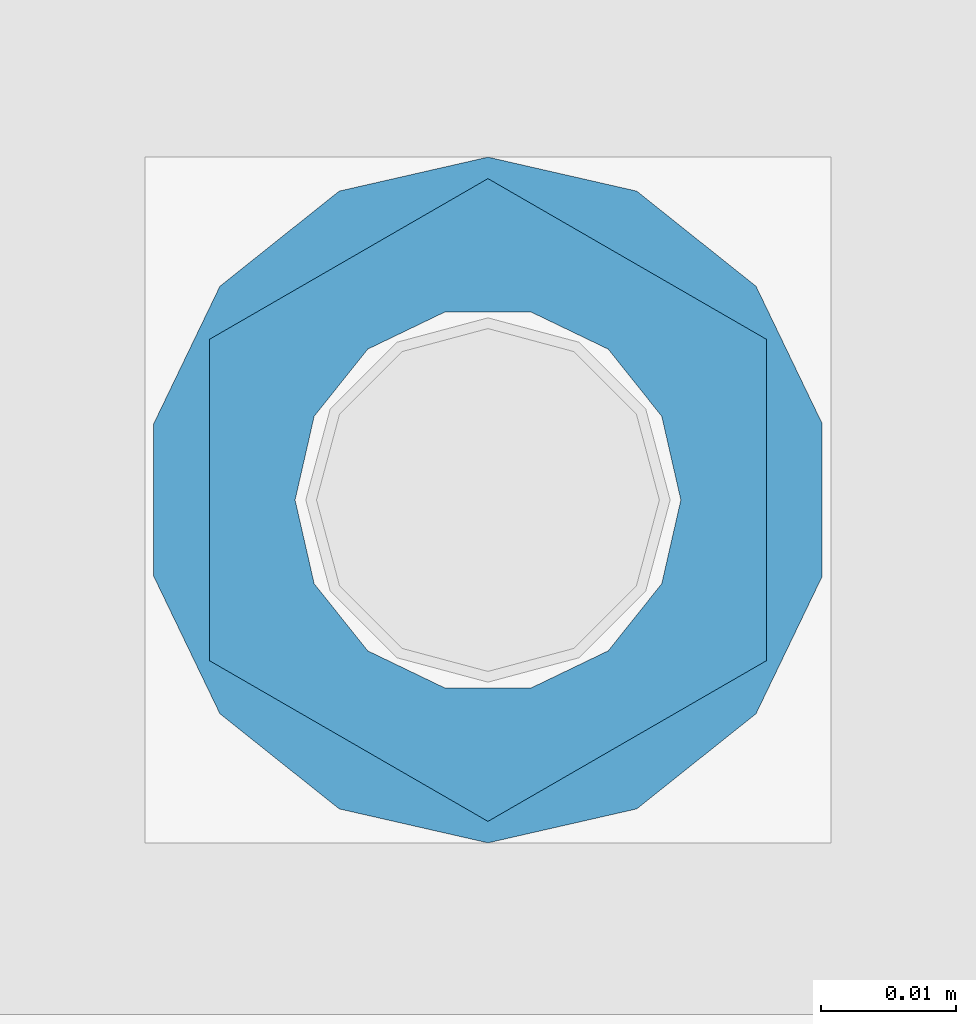
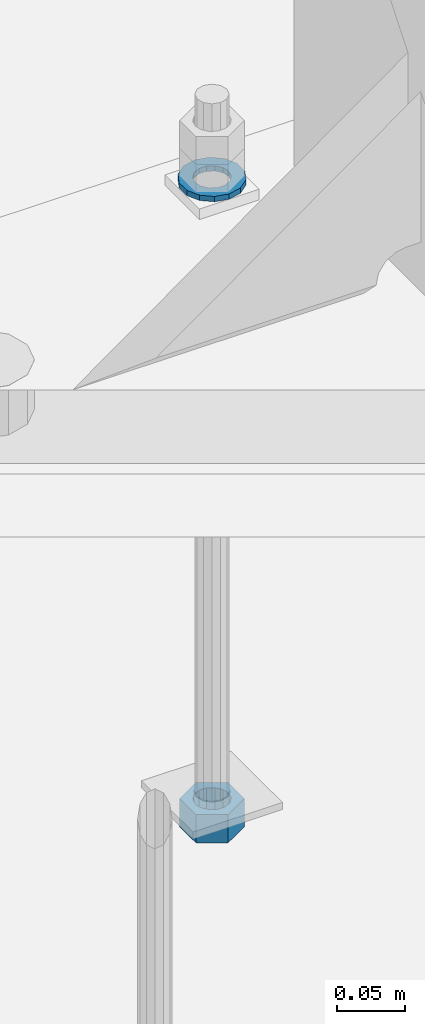
# One storey, part 1018 of 1763: 2 columns, 1 element without a shape of its own.
"""IFC2X3 building model written with IfcOpenShell, lengths in millimetres."""

from ifc_helpers import new_model, si_unit, frame, origin_with_axes, place, context, subcontext, project, spatial, faceted_brep, material, type_object, element, aggregate, save


model = new_model("IFC2X3")

# Units and contexts
model_context = context("Model", 3, precision=1e-05, world=origin_with_axes())
body_context = subcontext(model_context, "Body", "Model", "MODEL_VIEW")
ifc_project = project(units=[si_unit("LENGTHUNIT", "METRE", prefix="MILLI"), si_unit("AREAUNIT", "SQUARE_METRE"), si_unit("VOLUMEUNIT", "CUBIC_METRE"), si_unit("MASSUNIT", "GRAM", prefix="KILO"), si_unit("TIMEUNIT", "SECOND"), si_unit("PLANEANGLEUNIT", "RADIAN"), si_unit("SOLIDANGLEUNIT", "STERADIAN"), si_unit("THERMODYNAMICTEMPERATUREUNIT", "DEGREE_CELSIUS"), si_unit("LUMINOUSINTENSITYUNIT", "LUMEN")], contexts=[model_context])

# Site, building, storey
site_placement = place(None, origin_with_axes())
site = spatial("IfcSite", under=ifc_project, at=site_placement, CompositionType="ELEMENT")
building_placement = place(site_placement, origin_with_axes())
building = spatial("IfcBuilding", under=site, at=building_placement, Name="Undefined", CompositionType="ELEMENT")
storey_placement = place(building_placement, origin_with_axes())
storey = spatial("IfcBuildingStorey", under=building, at=storey_placement, Name="Undefined", CompositionType="ELEMENT", Elevation=0.0)

# Assembly, columns
assembly_placement = place(storey_placement, origin_with_axes())
assembly = element("IfcElementAssembly", 1, at=assembly_placement, inside=storey, Name="TEMPLATE", AssemblyPlace="NOTDEFINED", PredefinedType="RIGID_FRAME")
ifc_material_1 = material(Name="STEEL/A563")
column_type_1 = type_object("IfcColumnType", Name="1_HEAVY_HEX_NUT", PredefinedType="NOTDEFINED")
column_1_placement = place(assembly_placement, frame((-87121.4372736983, 52298.6, -762.000000000016), z_axis=(-1.0, 0.0, 0.0), x_axis=(0.0, 0.0, -1.0)))
column_1 = element("IfcColumn", 2, at=column_1_placement, type_object=column_type_1, material=ifc_material_1, Name="NUT", ObjectType="1_HEAVY_HEX_NUT", context=body_context, shape_type="Brep", body=[
    faceted_brep([(0.0, -23.8099994659424, 0.0), (0.0, -11.9099998474121, -20.6200008392334), (25.4, -11.9099998474121, -20.6200008392334), (25.4, -23.8099994659424, 0.0), (0.0, 11.9099998474121, -20.6200008392334), (25.4, 11.9099998474121, -20.6200008392334), (0.0, 23.8099994659424, 0.0), (25.4, 23.8099994659424, 0.0), (0.0, 11.9099998474121, 20.6200008392334), (25.4, 11.9099998474121, 20.6200008392334), (0.0, -11.9099998474121, 20.6200008392334), (25.4, -11.9099998474121, 20.6200008392334), (0.0, 0.0, 14.289999961853), (0.0, 6.20019861543551, 12.8748450879575), (25.4, 6.20019861543551, 12.8748450879502), (25.4, 0.0, 14.289999961853), (0.0, 11.1723718546418, 8.90966924477834), (25.4, 11.1723718546418, 8.90966924477834), (0.0, 13.9317198278877, 3.17982413774735), (25.4, 13.9317198278877, 3.17982413774007), (0.0, 13.9317198278877, -3.17982413774735), (25.4, 13.9317198278877, -3.17982413774007), (0.0, 11.1723718546418, -8.90966924477834), (25.4, 11.1723718546418, -8.90966924477834), (0.0, 6.20019861543551, -12.8748450879575), (25.4, 6.20019861543551, -12.8748450879502), (0.0, 0.0, -14.289999961853), (25.4, 0.0, -14.289999961853), (0.0, -6.20019861543551, -12.8748450879575), (25.4, -6.20019861543551, -12.8748450879502), (0.0, -11.1723718546418, -8.90966924477834), (25.4, -11.1723718546418, -8.90966924477834), (0.0, -13.9317198278877, -3.17982413774735), (25.4, -13.9317198278877, -3.17982413774007), (0.0, -13.9317198278877, 3.17982413774735), (25.4, -13.9317198278877, 3.17982413774007), (0.0, -11.1723718546418, 8.90966924477834), (25.4, -11.1723718546418, 8.90966924477834), (0.0, -6.20019861543551, 12.8748450879575), (25.4, -6.20019861543551, 12.8748450879502)], [[[0, 1, 2, 3]], [[1, 4, 5, 2]], [[4, 6, 7, 5]], [[6, 8, 9, 7]], [[8, 10, 11, 9]], [[10, 0, 3, 11]], [[12, 13, 14, 15]], [[13, 16, 17, 14]], [[16, 18, 19, 17]], [[18, 20, 21, 19]], [[20, 22, 23, 21]], [[22, 24, 25, 23]], [[24, 26, 27, 25]], [[26, 28, 29, 27]], [[28, 30, 31, 29]], [[30, 32, 33, 31]], [[32, 34, 35, 33]], [[34, 36, 37, 35]], [[36, 38, 39, 37]], [[38, 12, 15, 39]], [[5, 7, 9, 11, 3, 2], [17, 19, 21, 23, 25, 27, 29, 31, 33, 35, 37, 39, 15, 14]], [[10, 8, 6, 4, 1, 0], [38, 36, 34, 32, 30, 28, 26, 24, 22, 20, 18, 16, 13, 12]]]),
])
ifc_material_2 = material(Name="STEEL/F436")
column_type_2 = type_object("IfcColumnType", Name="1_WASHER", PredefinedType="NOTDEFINED")
column_2_placement = place(assembly_placement, frame((-87121.4372736983, 52298.6, -201.612500000016), z_axis=(-1.0, 0.0, 0.0), x_axis=(0.0, 0.0, -1.0)))
column_2 = element("IfcColumn", 3, at=column_2_placement, type_object=column_type_2, material=ifc_material_2, Name="WASHER", ObjectType="1_WASHER", context=body_context, shape_type="Brep", body=[
    faceted_brep([(0.0, -25.4000000000015, 0.0), (0.0, -22.8846089010258, -11.0206468080723), (4.76249999999982, -22.8846089010258, -11.0206468080723), (4.76249999999982, -25.3999996185303, 0.0), (0.0, -15.8366407293724, -19.8585193564359), (4.76249999999982, -15.8366407293724, -19.8585193564359), (0.0, -5.65203163760452, -24.7631685975066), (4.76249999999982, -5.65203163760452, -24.7631685975066), (0.0, 5.65203163760452, -24.7631685975066), (4.76249999999982, 5.65203163760452, -24.7631685975066), (0.0, 15.8366407293724, -19.8585193564359), (4.76249999999982, 15.8366407293724, -19.8585193564359), (0.0, 22.8846089010258, -11.0206468080723), (4.76249999999982, 22.8846089010258, -11.0206468080723), (0.0, 25.4000000000015, 0.0), (4.76249999999982, 25.3999996185303, 0.0), (0.0, 22.8846089010258, 11.0206468080723), (4.76249999999982, 22.8846089010258, 11.0206468080723), (0.0, 15.8366407293724, 19.8585193564359), (4.76249999999982, 15.8366407293724, 19.8585193564359), (0.0, 5.65203163760452, 24.7631685975066), (4.76249999999982, 5.65203163760452, 24.7631685975066), (0.0, -5.65203163760452, 24.7631685975066), (4.76249999999982, -5.65203163760452, 24.7631685975066), (0.0, -15.8366407293724, 19.8585193564359), (4.76249999999982, -15.8366407293724, 19.8585193564359), (0.0, -22.8846089010258, 11.0206468080723), (4.76249999999982, -22.8846089010258, 11.0206468080723), (0.0, 0.0, 14.289999961853), (0.0, 6.20019861543551, 12.8748450879575), (4.76249999999982, 6.20019861543551, 12.8748450879502), (4.76249999999982, 0.0, 14.289999961853), (0.0, 11.1723718546418, 8.90966924477834), (4.76249999999982, 11.1723718546418, 8.90966924477834), (0.0, 13.9317198278877, 3.17982413774735), (4.76249999999982, 13.9317198278877, 3.17982413774007), (0.0, 13.9317198278877, -3.17982413774735), (4.76249999999982, 13.9317198278877, -3.17982413774007), (0.0, 11.1723718546418, -8.90966924477834), (4.76249999999982, 11.1723718546418, -8.90966924477834), (0.0, 6.20019861543551, -12.8748450879575), (4.76249999999982, 6.20019861543551, -12.8748450879502), (0.0, 0.0, -14.289999961853), (4.76249999999982, 0.0, -14.289999961853), (0.0, -6.20019861543551, -12.8748450879575), (4.76249999999982, -6.20019861543551, -12.8748450879502), (0.0, -11.1723718546418, -8.90966924477834), (4.76249999999982, -11.1723718546418, -8.90966924477834), (0.0, -13.9317198278877, -3.17982413774735), (4.76249999999982, -13.9317198278877, -3.17982413774007), (0.0, -13.9317198278877, 3.17982413774735), (4.76249999999982, -13.9317198278877, 3.17982413774007), (0.0, -11.1723718546418, 8.90966924477834), (4.76249999999982, -11.1723718546418, 8.90966924477834), (0.0, -6.20019861543551, 12.8748450879575), (4.76249999999982, -6.20019861543551, 12.8748450879502)], [[[0, 1, 2, 3]], [[1, 4, 5, 2]], [[4, 6, 7, 5]], [[6, 8, 9, 7]], [[8, 10, 11, 9]], [[10, 12, 13, 11]], [[12, 14, 15, 13]], [[14, 16, 17, 15]], [[16, 18, 19, 17]], [[18, 20, 21, 19]], [[20, 22, 23, 21]], [[22, 24, 25, 23]], [[24, 26, 27, 25]], [[26, 0, 3, 27]], [[28, 29, 30, 31]], [[29, 32, 33, 30]], [[32, 34, 35, 33]], [[34, 36, 37, 35]], [[36, 38, 39, 37]], [[38, 40, 41, 39]], [[40, 42, 43, 41]], [[42, 44, 45, 43]], [[44, 46, 47, 45]], [[46, 48, 49, 47]], [[48, 50, 51, 49]], [[50, 52, 53, 51]], [[52, 54, 55, 53]], [[54, 28, 31, 55]], [[5, 7, 9, 11, 13, 15, 17, 19, 21, 23, 25, 27, 3, 2], [33, 35, 37, 39, 41, 43, 45, 47, 49, 51, 53, 55, 31, 30]], [[26, 24, 22, 20, 18, 16, 14, 12, 10, 8, 6, 4, 1, 0], [54, 52, 50, 48, 46, 44, 42, 40, 38, 36, 34, 32, 29, 28]]]),
])
aggregate(assembly, [column_2, column_1])

save(model, "model.ifc")
